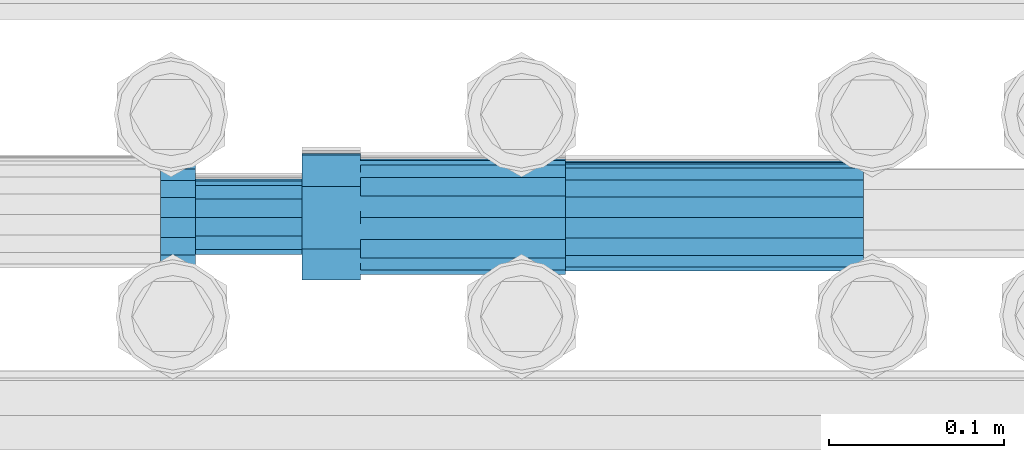
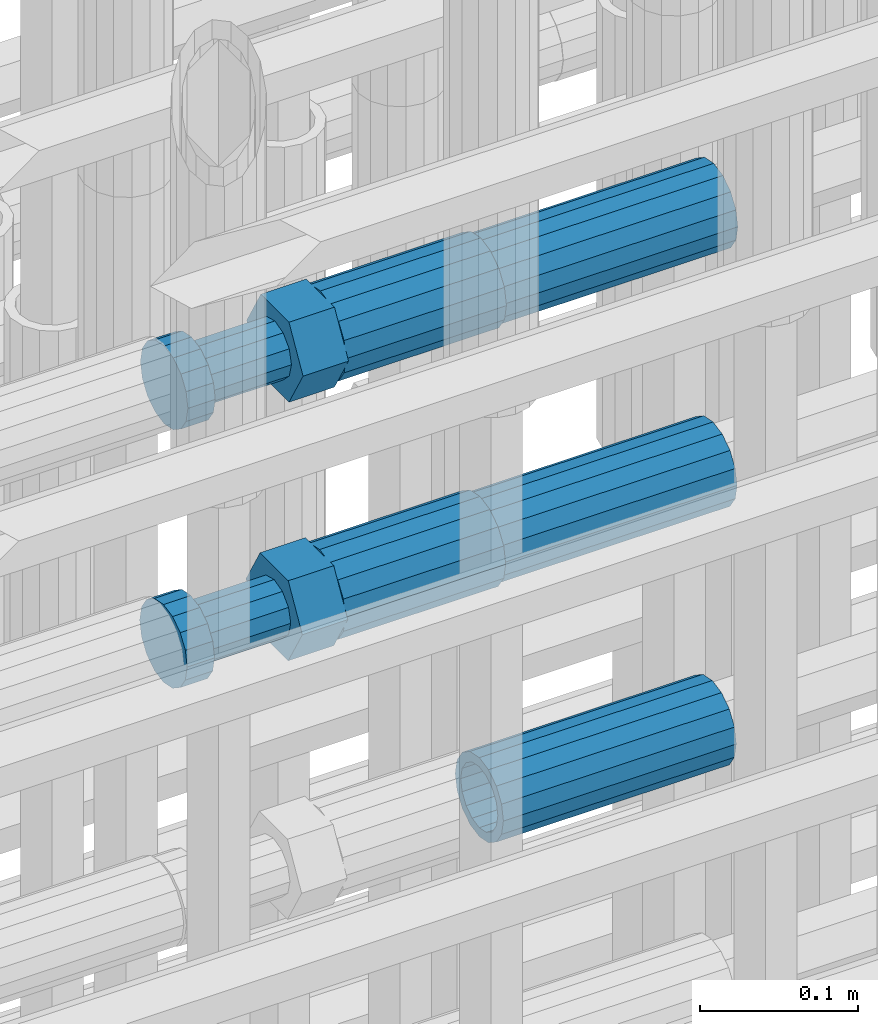
# One storey, part 26 of 119: 5 beams.
"""IFC2X3 building model written with IfcOpenShell, lengths in millimetres."""

from ifc_helpers import new_model, si_unit, frame, origin_with_axes, place, context, subcontext, project, spatial, faceted_brep, material, type_object, element, save


model = new_model("IFC2X3")

# Units and contexts
model_context = context("Model", 3, precision=1e-05, world=origin_with_axes())
body_context = subcontext(model_context, "Body", "Model", "MODEL_VIEW")
ifc_project = project(units=[si_unit("LENGTHUNIT", "METRE", prefix="MILLI"), si_unit("AREAUNIT", "SQUARE_METRE"), si_unit("VOLUMEUNIT", "CUBIC_METRE"), si_unit("MASSUNIT", "GRAM", prefix="KILO"), si_unit("TIMEUNIT", "SECOND"), si_unit("PLANEANGLEUNIT", "RADIAN"), si_unit("SOLIDANGLEUNIT", "STERADIAN"), si_unit("THERMODYNAMICTEMPERATUREUNIT", "DEGREE_CELSIUS"), si_unit("LUMINOUSINTENSITYUNIT", "LUMEN")], contexts=[model_context])

# Site, building, storey
site_placement = place(None, origin_with_axes())
site = spatial("IfcSite", under=ifc_project, at=site_placement, CompositionType="ELEMENT")
building_placement = place(site_placement, origin_with_axes())
building = spatial("IfcBuilding", under=site, at=building_placement, Name="Undefined", CompositionType="ELEMENT")
storey_placement = place(building_placement, origin_with_axes())
storey = spatial("IfcBuildingStorey", under=building, at=storey_placement, Name="Undefined", CompositionType="ELEMENT", Elevation=0.0)

# Beams
ifc_material = material(Name="STEEL/S275")
beam_type_1 = type_object("IfcBeamType", PredefinedType="NOTDEFINED")
beam_1_placement = place(storey_placement, frame((2035520.01345925, 6205210.28560864, 20746.6568409387), z_axis=(0.0, 0.0, 1.0), x_axis=(-0.999999999998145, -1.92600247614167e-06, 0.0)))
element("IfcBeam", 1, at=beam_1_placement, inside=storey, type_object=beam_type_1, material=ifc_material, Name="AG40N", context=body_context, shape_type="Brep", body=[
    faceted_brep([(1.62981450557709e-09, -23.4999999990687, 0.0), (7.45058059692383e-09, -21.7111690142192, 8.99306066057534), (170.000002125278, -21.711168999318, 8.99306066022245), (170.000002127141, -23.4999999844003, -3.66071617463604e-10), (4.65661287307739e-09, -16.6170093587134, 16.6170093578889), (170.000002122484, -16.6170093440451, 16.6170093575288), (1.86264514923096e-09, -8.99306066217832, 21.7111690140277), (170.000002118759, -8.99306064750999, 21.7111690136603), (2.3283064365387e-10, 9.31322574615479e-10, 23.5), (170.000002114102, 1.28056854009628e-08, 23.4999999996485), (-6.51925802230835e-09, 8.99306065868586, 21.7111690140241), (170.00000211224, 8.99306067335419, 21.7111690136639), (-7.45058059692383e-09, 16.6170093561523, 16.6170093578853), (170.000002109446, 16.6170093708206, 16.6170093575324), (-9.31322574615479e-09, 21.711169013055, 8.99306066057534), (170.000002108514, 21.7111690277234, 8.99306066022245), (-1.16415321826935e-09, 23.5000000009313, 0.0), (170.000002108514, 23.5000000144355, -3.66071617463604e-10), (-8.38190317153931e-09, 21.7111690151505, -8.99306066059444), (170.000002110377, 21.7111690300517, -8.9930606609546), (-5.58793544769287e-09, 16.6170093598776, -16.6170093579008), (170.000002113171, 16.6170093745459, -16.6170093582609), (-9.31322574615479e-10, 8.99306066334248, -21.7111690140396), (170.000002115965, 8.99306067801081, -21.7111690143961), (2.3283064365387e-10, 9.31322574615479e-10, -23.5), (170.00000211969, 1.7927959561348e-08, -23.5000000003843), (5.58793544769287e-09, -8.99306065752171, -21.7111690140396), (170.000002123415, -8.99306064285338, -21.7111690143961), (8.38190317153931e-09, -16.6170093549881, -16.6170093579008), (170.000002125278, -16.6170093403198, -16.6170093582646), (9.31322574615479e-09, -21.7111690121237, -8.99306066059444), (170.000002127141, -21.7111689972226, -8.9930606609546), (1.11758708953857e-08, -30.4999999990687, -9.54969436861575e-12), (1.30385160446167e-08, -28.1783257392235, -11.6718446871514), (170.000002129003, -28.1783257243223, -11.6718446875116), (170.000002129935, -30.4999999841675, -3.66071617463604e-10), (1.02445483207703e-08, -21.5667568228673, -21.5667568262129), (170.000002128072, -21.566756808199, -21.5667568265694), (7.45058059692383e-09, -11.6718446831219, -28.1783257416196), (170.000002125278, -11.6718446684536, -28.1783257419834), (3.72529029846191e-09, 3.95812094211578e-09, -30.5000000000277), (170.00000211969, 1.83936208486557e-08, -30.5000000003879), (-9.31322574615479e-10, 11.6718446905725, -28.1783257416232), (170.000002115965, 11.6718447052408, -28.1783257419797), (-6.51925802230835e-09, 21.5667568286881, -21.5667568262093), (170.000002110377, 21.5667568433564, -21.5667568265694), (-9.31322574615479e-09, 28.178325742716, -11.6718446871478), (170.000002108514, 28.1783257573843, -11.6718446875079), (-1.21071934700012e-08, 30.5, -5.91171556152403e-12), (170.000002106652, 30.5000000144355, -3.62433638656512e-10), (-1.21071934700012e-08, 28.1783257401548, 11.6718446871359), (170.00000210572, 28.1783257548232, 11.6718446867794), (-1.02445483207703e-08, 21.5667568240315, 21.5667568261974), (170.000002107583, 21.566756838467, 21.5667568258409), (-7.45058059692383e-09, 11.671844684286, 28.1783257416041), (170.000002110377, 11.6718446989544, 28.178325741244), (-2.79396772384644e-09, -2.56113708019257e-09, 30.5000000000159), (170.000002114102, 1.18743628263474e-08, 30.4999999996558), (1.86264514923096e-09, -11.6718446896411, 28.1783257416114), (170.000002118759, -11.67184467474, 28.178325741244), (7.45058059692383e-09, -21.5667568275239, 21.5667568261974), (170.000002123415, -21.5667568126228, 21.5667568258373), (1.02445483207703e-08, -28.1783257415518, 11.6718446871359), (170.000002127141, -28.1783257271163, 11.6718446867794)], [[[0, 1, 2, 3]], [[1, 4, 5, 2]], [[4, 6, 7, 5]], [[6, 8, 9, 7]], [[8, 10, 11, 9]], [[10, 12, 13, 11]], [[12, 14, 15, 13]], [[14, 16, 17, 15]], [[16, 18, 19, 17]], [[18, 20, 21, 19]], [[20, 22, 23, 21]], [[22, 24, 25, 23]], [[24, 26, 27, 25]], [[26, 28, 29, 27]], [[28, 30, 31, 29]], [[30, 0, 3, 31]], [[32, 33, 34, 35]], [[33, 36, 37, 34]], [[36, 38, 39, 37]], [[38, 40, 41, 39]], [[40, 42, 43, 41]], [[42, 44, 45, 43]], [[44, 46, 47, 45]], [[46, 48, 49, 47]], [[48, 50, 51, 49]], [[50, 52, 53, 51]], [[52, 54, 55, 53]], [[54, 56, 57, 55]], [[56, 58, 59, 57]], [[58, 60, 61, 59]], [[60, 62, 63, 61]], [[62, 32, 35, 63]], [[37, 39, 41, 43, 45, 47, 49, 51, 53, 55, 57, 59, 61, 63, 35, 34], [5, 7, 9, 11, 13, 15, 17, 19, 21, 23, 25, 27, 29, 31, 3, 2]], [[62, 60, 58, 56, 54, 52, 50, 48, 46, 44, 42, 40, 38, 36, 33, 32], [30, 28, 26, 24, 22, 20, 18, 16, 14, 12, 10, 8, 6, 4, 1, 0]]]),
])
beam_2_placement = place(storey_placement, frame((2035520.01345925, 6205211.20560864, 20546.6568409387), z_axis=(0.0, 0.0, 1.0), x_axis=(-0.999999999998145, -1.92600247614167e-06, 0.0)))
element("IfcBeam", 2, at=beam_2_placement, inside=storey, type_object=beam_type_1, material=ifc_material, Name="AG40N", context=body_context, shape_type="Brep", body=[
    faceted_brep([(1.62981450557709e-09, -23.4999999990687, 0.0), (7.45058059692383e-09, -21.7111690142192, 8.99306066057534), (170.000002125278, -21.711168999318, 8.99306066022245), (170.000002127141, -23.4999999844003, -3.66071617463604e-10), (4.65661287307739e-09, -16.6170093587134, 16.6170093578889), (170.000002122484, -16.6170093440451, 16.6170093575288), (1.86264514923096e-09, -8.99306066217832, 21.7111690140277), (170.000002118759, -8.99306064750999, 21.7111690136603), (2.3283064365387e-10, 9.31322574615479e-10, 23.5), (170.000002114102, 1.28056854009628e-08, 23.4999999996485), (-6.51925802230835e-09, 8.99306065868586, 21.7111690140241), (170.00000211224, 8.99306067335419, 21.7111690136639), (-7.45058059692383e-09, 16.6170093561523, 16.6170093578853), (170.000002109446, 16.6170093708206, 16.6170093575324), (-9.31322574615479e-09, 21.711169013055, 8.99306066057534), (170.000002108514, 21.7111690277234, 8.99306066022245), (-1.16415321826935e-09, 23.5000000009313, 0.0), (170.000002108514, 23.5000000144355, -3.66071617463604e-10), (-8.38190317153931e-09, 21.7111690151505, -8.99306066059444), (170.000002110377, 21.7111690300517, -8.9930606609546), (-5.58793544769287e-09, 16.6170093598776, -16.6170093579008), (170.000002113171, 16.6170093745459, -16.6170093582609), (-9.31322574615479e-10, 8.99306066334248, -21.7111690140396), (170.000002115965, 8.99306067801081, -21.7111690143961), (2.3283064365387e-10, 9.31322574615479e-10, -23.5), (170.00000211969, 1.7927959561348e-08, -23.5000000003843), (5.58793544769287e-09, -8.99306065752171, -21.7111690140396), (170.000002123415, -8.99306064285338, -21.7111690143961), (8.38190317153931e-09, -16.6170093549881, -16.6170093579008), (170.000002125278, -16.6170093403198, -16.6170093582646), (9.31322574615479e-09, -21.7111690121237, -8.99306066059444), (170.000002127141, -21.7111689972226, -8.9930606609546), (1.11758708953857e-08, -30.4999999990687, -9.54969436861575e-12), (1.30385160446167e-08, -28.1783257392235, -11.6718446871514), (170.000002129003, -28.1783257243223, -11.6718446875116), (170.000002129935, -30.4999999841675, -3.66071617463604e-10), (1.02445483207703e-08, -21.5667568228673, -21.5667568262129), (170.000002128072, -21.566756808199, -21.5667568265694), (7.45058059692383e-09, -11.6718446831219, -28.1783257416196), (170.000002125278, -11.6718446684536, -28.1783257419834), (3.72529029846191e-09, 3.95812094211578e-09, -30.5000000000277), (170.00000211969, 1.83936208486557e-08, -30.5000000003879), (-9.31322574615479e-10, 11.6718446905725, -28.1783257416232), (170.000002115965, 11.6718447052408, -28.1783257419797), (-6.51925802230835e-09, 21.5667568286881, -21.5667568262093), (170.000002110377, 21.5667568433564, -21.5667568265694), (-9.31322574615479e-09, 28.178325742716, -11.6718446871478), (170.000002108514, 28.1783257573843, -11.6718446875079), (-1.21071934700012e-08, 30.5, -5.91171556152403e-12), (170.000002106652, 30.5000000144355, -3.62433638656512e-10), (-1.21071934700012e-08, 28.1783257401548, 11.6718446871359), (170.00000210572, 28.1783257548232, 11.6718446867794), (-1.02445483207703e-08, 21.5667568240315, 21.5667568261974), (170.000002107583, 21.566756838467, 21.5667568258409), (-7.45058059692383e-09, 11.671844684286, 28.1783257416041), (170.000002110377, 11.6718446989544, 28.178325741244), (-2.79396772384644e-09, -2.56113708019257e-09, 30.5000000000159), (170.000002114102, 1.18743628263474e-08, 30.4999999996558), (1.86264514923096e-09, -11.6718446896411, 28.1783257416114), (170.000002118759, -11.67184467474, 28.178325741244), (7.45058059692383e-09, -21.5667568275239, 21.5667568261974), (170.000002123415, -21.5667568126228, 21.5667568258373), (1.02445483207703e-08, -28.1783257415518, 11.6718446871359), (170.000002127141, -28.1783257271163, 11.6718446867794)], [[[0, 1, 2, 3]], [[1, 4, 5, 2]], [[4, 6, 7, 5]], [[6, 8, 9, 7]], [[8, 10, 11, 9]], [[10, 12, 13, 11]], [[12, 14, 15, 13]], [[14, 16, 17, 15]], [[16, 18, 19, 17]], [[18, 20, 21, 19]], [[20, 22, 23, 21]], [[22, 24, 25, 23]], [[24, 26, 27, 25]], [[26, 28, 29, 27]], [[28, 30, 31, 29]], [[30, 0, 3, 31]], [[32, 33, 34, 35]], [[33, 36, 37, 34]], [[36, 38, 39, 37]], [[38, 40, 41, 39]], [[40, 42, 43, 41]], [[42, 44, 45, 43]], [[44, 46, 47, 45]], [[46, 48, 49, 47]], [[48, 50, 51, 49]], [[50, 52, 53, 51]], [[52, 54, 55, 53]], [[54, 56, 57, 55]], [[56, 58, 59, 57]], [[58, 60, 61, 59]], [[60, 62, 63, 61]], [[62, 32, 35, 63]], [[37, 39, 41, 43, 45, 47, 49, 51, 53, 55, 57, 59, 61, 63, 35, 34], [5, 7, 9, 11, 13, 15, 17, 19, 21, 23, 25, 27, 29, 31, 3, 2]], [[62, 60, 58, 56, 54, 52, 50, 48, 46, 44, 42, 40, 38, 36, 33, 32], [30, 28, 26, 24, 22, 20, 18, 16, 14, 12, 10, 8, 6, 4, 1, 0]]]),
])
beam_3_placement = place(storey_placement, frame((2035520.01345925, 6205212.13560864, 20346.6568409387), z_axis=(0.0, 0.0, 1.0), x_axis=(-0.999999999998145, -1.92600247614167e-06, 0.0)))
element("IfcBeam", 3, at=beam_3_placement, inside=storey, type_object=beam_type_1, material=ifc_material, Name="AG40N", context=body_context, shape_type="Brep", body=[
    faceted_brep([(1.62981450557709e-09, -23.4999999990687, 0.0), (7.45058059692383e-09, -21.7111690142192, 8.99306066057534), (170.000002125278, -21.711168999318, 8.99306066022245), (170.000002127141, -23.4999999844003, -3.66071617463604e-10), (4.65661287307739e-09, -16.6170093587134, 16.6170093578889), (170.000002122484, -16.6170093440451, 16.6170093575288), (1.86264514923096e-09, -8.99306066217832, 21.7111690140277), (170.000002118759, -8.99306064750999, 21.7111690136603), (2.3283064365387e-10, 9.31322574615479e-10, 23.5), (170.000002114102, 1.28056854009628e-08, 23.4999999996485), (-6.51925802230835e-09, 8.99306065868586, 21.7111690140241), (170.00000211224, 8.99306067335419, 21.7111690136639), (-7.45058059692383e-09, 16.6170093561523, 16.6170093578853), (170.000002109446, 16.6170093708206, 16.6170093575324), (-9.31322574615479e-09, 21.711169013055, 8.99306066057534), (170.000002108514, 21.7111690277234, 8.99306066022245), (-1.16415321826935e-09, 23.5000000009313, 0.0), (170.000002108514, 23.5000000144355, -3.66071617463604e-10), (-8.38190317153931e-09, 21.7111690151505, -8.99306066059444), (170.000002110377, 21.7111690300517, -8.9930606609546), (-5.58793544769287e-09, 16.6170093598776, -16.6170093579008), (170.000002113171, 16.6170093745459, -16.6170093582609), (-9.31322574615479e-10, 8.99306066334248, -21.7111690140396), (170.000002115965, 8.99306067801081, -21.7111690143961), (2.3283064365387e-10, 9.31322574615479e-10, -23.5), (170.00000211969, 1.7927959561348e-08, -23.5000000003843), (5.58793544769287e-09, -8.99306065752171, -21.7111690140396), (170.000002123415, -8.99306064285338, -21.7111690143961), (8.38190317153931e-09, -16.6170093549881, -16.6170093579008), (170.000002125278, -16.6170093403198, -16.6170093582646), (9.31322574615479e-09, -21.7111690121237, -8.99306066059444), (170.000002127141, -21.7111689972226, -8.9930606609546), (1.11758708953857e-08, -30.4999999990687, -9.54969436861575e-12), (1.30385160446167e-08, -28.1783257392235, -11.6718446871514), (170.000002129003, -28.1783257243223, -11.6718446875116), (170.000002129935, -30.4999999841675, -3.66071617463604e-10), (1.02445483207703e-08, -21.5667568228673, -21.5667568262129), (170.000002128072, -21.566756808199, -21.5667568265694), (7.45058059692383e-09, -11.6718446831219, -28.1783257416196), (170.000002125278, -11.6718446684536, -28.1783257419834), (3.72529029846191e-09, 3.95812094211578e-09, -30.5000000000277), (170.00000211969, 1.83936208486557e-08, -30.5000000003879), (-9.31322574615479e-10, 11.6718446905725, -28.1783257416232), (170.000002115965, 11.6718447052408, -28.1783257419797), (-6.51925802230835e-09, 21.5667568286881, -21.5667568262093), (170.000002110377, 21.5667568433564, -21.5667568265694), (-9.31322574615479e-09, 28.178325742716, -11.6718446871478), (170.000002108514, 28.1783257573843, -11.6718446875079), (-1.21071934700012e-08, 30.5, -5.91171556152403e-12), (170.000002106652, 30.5000000144355, -3.62433638656512e-10), (-1.21071934700012e-08, 28.1783257401548, 11.6718446871359), (170.00000210572, 28.1783257548232, 11.6718446867794), (-1.02445483207703e-08, 21.5667568240315, 21.5667568261974), (170.000002107583, 21.566756838467, 21.5667568258409), (-7.45058059692383e-09, 11.671844684286, 28.1783257416041), (170.000002110377, 11.6718446989544, 28.178325741244), (-2.79396772384644e-09, -2.56113708019257e-09, 30.5000000000159), (170.000002114102, 1.18743628263474e-08, 30.4999999996558), (1.86264514923096e-09, -11.6718446896411, 28.1783257416114), (170.000002118759, -11.67184467474, 28.178325741244), (7.45058059692383e-09, -21.5667568275239, 21.5667568261974), (170.000002123415, -21.5667568126228, 21.5667568258373), (1.02445483207703e-08, -28.1783257415518, 11.6718446871359), (170.000002127141, -28.1783257271163, 11.6718446867794)], [[[0, 1, 2, 3]], [[1, 4, 5, 2]], [[4, 6, 7, 5]], [[6, 8, 9, 7]], [[8, 10, 11, 9]], [[10, 12, 13, 11]], [[12, 14, 15, 13]], [[14, 16, 17, 15]], [[16, 18, 19, 17]], [[18, 20, 21, 19]], [[20, 22, 23, 21]], [[22, 24, 25, 23]], [[24, 26, 27, 25]], [[26, 28, 29, 27]], [[28, 30, 31, 29]], [[30, 0, 3, 31]], [[32, 33, 34, 35]], [[33, 36, 37, 34]], [[36, 38, 39, 37]], [[38, 40, 41, 39]], [[40, 42, 43, 41]], [[42, 44, 45, 43]], [[44, 46, 47, 45]], [[46, 48, 49, 47]], [[48, 50, 51, 49]], [[50, 52, 53, 51]], [[52, 54, 55, 53]], [[54, 56, 57, 55]], [[56, 58, 59, 57]], [[58, 60, 61, 59]], [[60, 62, 63, 61]], [[62, 32, 35, 63]], [[37, 39, 41, 43, 45, 47, 49, 51, 53, 55, 57, 59, 61, 63, 35, 34], [5, 7, 9, 11, 13, 15, 17, 19, 21, 23, 25, 27, 29, 31, 3, 2]], [[62, 60, 58, 56, 54, 52, 50, 48, 46, 44, 42, 40, 38, 36, 33, 32], [30, 28, 26, 24, 22, 20, 18, 16, 14, 12, 10, 8, 6, 4, 1, 0]]]),
])
beam_type_2 = type_object("IfcBeamType", Name="ROD65", PredefinedType="NOTDEFINED")
beam_4_placement = place(storey_placement, frame((2035350.01345925, 6205210.28544664, 20746.6568409387), z_axis=(0.0, 0.0, 1.0), x_axis=(-0.999999999998145, -1.92600247614167e-06, 0.0)))
element("IfcBeam", 4, at=beam_4_placement, inside=storey, type_object=beam_type_2, material=ifc_material, Name="AGB40", ObjectType="ROD65", context=body_context, shape_type="Brep", body=[
    faceted_brep([(116.999999999069, 17.8249999252148, 30.8738056446964), (116.999999998137, 22.0056957420893, 23.632628078838), (116.999999999069, 12.4372115600854, 30.0260848066173), (116.999999999069, 8.17543111252598, 30.8738056446964), (117.000000000931, -17.8250000746921, 30.8738056446964), (150.200000001118, -17.8250000723638, 30.8738056446964), (150.199999999255, 17.8249999275431, 30.8738056446964), (117.000000000931, -8.17543109622784, 30.8738056446964), (117.000000001863, -22.0056959956419, 23.6326278985034), (117.000000000931, -12.4372115437873, 30.0260848066173), (117.000000001863, -35.6500000746455, -2.18278728425503e-10), (150.200000002049, -35.6500000723172, -2.18278728425503e-10), (117.000000001863, -30.8443149488885, 8.32369080289209), (117.000000001863, -30.8443149488885, -8.32369080355784), (117.000000002794, -32.4999999918509, 0.0), (117.000000000931, -17.8250000746921, -30.873805645133), (150.200000001118, -17.8250000723638, -30.873805645133), (117.000000001863, -22.0056959961075, -23.6326278982269), (117.000000000931, -8.17543109389953, -30.873805645133), (117.000000000931, -12.4372115437873, -30.0260848066173), (116.999999999069, 17.8249999252148, -30.873805645133), (150.199999999255, 17.8249999275431, -30.873805645133), (116.999999999069, 8.17543111019768, -30.873805645133), (116.999999999069, 12.4372115600854, -30.0260848066173), (116.999999998137, 22.005695742555, -23.6326280785652), (116.999999998137, 35.6499999251682, -2.18278728425503e-10), (150.199999998324, 35.6499999277294, -2.18278728425503e-10), (116.999999998137, 30.8443150522653, -8.32369036550881), (116.999999997206, 32.5000000081491, 0.0), (116.999999998137, 30.8443150522653, 8.32369036483942), (1.86264514923096e-09, -22.9809703885112, 22.9809703885621), (1.86264514923096e-09, -30.0260848065373, 12.4372115518672), (117.000000001863, -30.0260847983882, 12.4372115518672), (117.000000001863, -22.9809703803621, 22.9809703885621), (-1.86264514923096e-09, 22.9809703885112, -22.9809703885621), (-1.86264514923096e-09, 30.0260848065373, -12.4372115518672), (116.999999998137, 30.0260848146863, -12.4372115518672), (116.999999998137, 22.9809703966603, -22.9809703885621), (1.86264514923096e-09, -30.0260848065373, -12.4372115518672), (1.86264514923096e-09, -22.9809703885112, -22.9809703885621), (117.000000001863, -22.9809703803621, -22.9809703885621), (117.000000001863, -30.0260847983882, -12.4372115518672), (9.31322574615479e-10, -12.4372115519363, 30.0260848066173), (0.0, 0.0, 32.5), (-9.31322574615479e-10, 12.4372115519363, 30.0260848066173), (-1.86264514923096e-09, 22.9809703885112, 22.9809703885621), (-1.86264514923096e-09, 30.0260848065373, 12.4372115518672), (-2.79396772384644e-09, 32.5, 0.0), (-9.31322574615479e-10, 12.4372115519363, -30.0260848066173), (0.0, 0.0, -32.5), (9.31322574615479e-10, -12.4372115519363, -30.0260848066173), (2.79396772384644e-09, -32.5, 0.0), (116.999999998137, 22.9809703966603, 22.9809703885621), (116.999999998137, 30.0260848146863, 12.4372115518672), (117.0, 8.14907252788544e-09, -32.5), (117.0, 8.14907252788544e-09, 32.5), (150.200000000186, -10.5000000959262, 18.1865334791873), (150.199999999255, -9.59262251853943e-08, 20.9999999997126), (150.199999998324, 10.4999999040738, 18.1865334791873), (150.199999997392, 18.1865333835594, 10.4999999997126), (150.199999997392, 20.9999999040738, -2.87400325760245e-10), (150.199999997392, 18.1865333835594, -10.5000000002874), (150.199999998324, 10.4999999040738, -18.1865334797621), (150.199999999255, -9.59262251853943e-08, -21.0000000002874), (150.200000000186, -10.5000000959262, -18.1865334797621), (150.200000000186, -18.1865335754119, -10.5000000002874), (150.200000001118, -21.0000000959262, -2.87400325760245e-10), (150.200000000186, -18.1865335754119, 10.4999999997126), (210.979999999516, 10.4999999082647, 18.1865334791873), (210.979999999516, -9.17352735996246e-08, 20.9999999997126), (210.979999997653, 18.1865333877504, 10.4999999997126), (210.979999997653, 20.9999999082647, -2.87400325760245e-10), (210.979999997653, 18.1865333877504, -10.5000000002874), (210.979999999516, 10.4999999082647, -18.1865334797621), (210.979999999516, -9.17352735996246e-08, -21.0000000002874), (210.979999999516, -10.5000000917353, -18.1865334797621), (210.980000000447, -18.1865335712209, -10.5000000002874), (210.980000001378, -21.0000000917353, -2.87400325760245e-10), (210.980000000447, -18.1865335712209, 10.4999999997126), (210.979999999516, -10.5000000917353, 18.1865334791873), (211.001368402503, -27.7269939335529, -11.4911163272045), (211.003082515672, -21.2238095656503, -21.2238154190527), (231.002518340945, -21.2131946226582, -21.2132004554769), (231.000804228708, -27.7163789905608, -11.4805013636287), (211.001368415542, -11.4911086384673, -27.7269970399575), (231.000804241747, -11.4804936954752, -27.7163820763781), (210.996487061493, -0.0106066407170147, -30.0106107396168), (230.995922887698, 8.30227509140968e-06, -29.999995776041), (210.98918159306, 11.4698940692469, -27.7269970332745), (230.988617419265, 11.4805090120062, -27.7163820696951), (210.980564201251, 21.2025913291145, -21.2238154067054), (230.980000027455, 21.2132062721066, -21.2132004431296), (210.971946807578, 27.7057702087332, -11.4911163110701), (230.971382633783, 27.7163851517253, -11.4805013474943), (210.964641331695, 29.9893806746695, -0.0106149565435771), (230.9640771579, 29.9999956176616, 7.03221303410828e-09), (210.959759964608, 27.7057637346443, 11.4698863966551), (230.959195790812, 27.7163786776364, 11.4805013602345), (210.958045851439, 21.2025793667417, 21.2025854885032), (230.957481677644, 21.2131943097338, 21.2132004520827), (210.959759951569, 11.4698784395587, 27.705767109408), (230.959195776843, 11.4804933823179, 27.7163820729838), (210.964641305618, -0.0106235581915826, 29.9893808090674), (230.964077131823, -8.61519947648048e-06, 29.9999957726432), (210.971946774051, -11.4911242681555, 27.7057671027251), (230.971382599324, -11.4805093251634, 27.7163820663009), (210.98056416586, -21.2238215280231, 21.2025854761559), (230.979999991134, -21.2132065852638, 21.2132004397354), (210.989181559533, -27.7270004076418, 11.4698863805206), (230.988617384806, -27.7163854646496, 11.4805013441), (210.996487035416, -30.0106108735781, -0.0106149740058754), (230.995922861621, -29.999995930586, -1.04300852399319e-08)], [[[0, 1, 2, 3]], [[4, 5, 6, 0, 3, 7]], [[8, 4, 7, 9]], [[10, 11, 5, 4, 8, 12]], [[13, 10, 12, 14]], [[15, 16, 11, 10, 13, 17]], [[18, 15, 17, 19]], [[20, 21, 16, 15, 18, 22]], [[20, 22, 23, 24]], [[25, 26, 21, 20, 24, 27]], [[25, 27, 28, 29]], [[30, 31, 32, 33]], [[34, 35, 36, 37]], [[38, 39, 40, 41]], [[31, 30, 42, 43, 44, 45, 46, 47, 35, 34, 48, 49, 50, 39, 38, 51]], [[46, 45, 52, 53]], [[28, 47, 46, 53, 29]], [[27, 36, 35, 47, 28]], [[24, 37, 36, 27]], [[23, 48, 34, 37, 24]], [[22, 54, 49, 48, 23]], [[18, 54, 22]], [[19, 50, 49, 54, 18]], [[17, 40, 39, 50, 19]], [[13, 41, 40, 17]], [[14, 51, 38, 41, 13]], [[12, 32, 31, 51, 14]], [[8, 33, 32, 12]], [[9, 42, 30, 33, 8]], [[7, 55, 43, 42, 9]], [[3, 55, 7]], [[2, 44, 43, 55, 3]], [[1, 52, 45, 44, 2]], [[29, 53, 52, 1]], [[0, 6, 26, 25, 29, 1]], [[5, 11, 16, 21, 26, 6], [56, 57, 58, 59, 60, 61, 62, 63, 64, 65, 66, 67]], [[68, 58, 57, 69]], [[70, 59, 58, 68]], [[71, 60, 59, 70]], [[72, 61, 60, 71]], [[73, 62, 61, 72]], [[74, 63, 62, 73]], [[75, 64, 63, 74]], [[76, 65, 64, 75]], [[77, 66, 65, 76]], [[78, 67, 66, 77]], [[79, 56, 67, 78]], [[69, 57, 56, 79]], [[80, 81, 82, 83]], [[81, 84, 85, 82]], [[84, 86, 87, 85]], [[86, 88, 89, 87]], [[88, 90, 91, 89]], [[90, 92, 93, 91]], [[92, 94, 95, 93]], [[94, 96, 97, 95]], [[96, 98, 99, 97]], [[98, 100, 101, 99]], [[100, 102, 103, 101]], [[102, 104, 105, 103]], [[104, 106, 107, 105]], [[106, 108, 109, 107]], [[108, 110, 111, 109]], [[82, 85, 87, 89, 91, 93, 95, 97, 99, 101, 103, 105, 107, 109, 111, 83]], [[110, 80, 83, 111]], [[108, 106, 104, 102, 100, 98, 96, 94, 92, 90, 88, 86, 84, 81, 80, 110], [78, 77, 76, 75, 74, 73, 72, 71, 70, 68, 69, 79]]]),
])
beam_5_placement = place(storey_placement, frame((2035350.01345925, 6205211.20544664, 20546.6568409387), z_axis=(0.0, 0.0, 1.0), x_axis=(-0.999999999998145, -1.92600247614167e-06, 0.0)))
element("IfcBeam", 5, at=beam_5_placement, inside=storey, type_object=beam_type_2, material=ifc_material, Name="AGB40", ObjectType="ROD65", context=body_context, shape_type="Brep", body=[
    faceted_brep([(116.999999999069, 17.8249999252148, 30.8738056446964), (116.999999998137, 22.0056957420893, 23.632628078838), (116.999999999069, 12.4372115600854, 30.0260848066173), (116.999999999069, 8.17543111252598, 30.8738056446964), (117.000000000931, -17.8250000746921, 30.8738056446964), (150.200000001118, -17.8250000723638, 30.8738056446964), (150.199999999255, 17.8249999275431, 30.8738056446964), (117.000000000931, -8.17543109622784, 30.8738056446964), (117.000000001863, -22.0056959956419, 23.6326278985034), (117.000000000931, -12.4372115437873, 30.0260848066173), (117.000000001863, -35.6500000746455, -2.18278728425503e-10), (150.200000002049, -35.6500000723172, -2.18278728425503e-10), (117.000000001863, -30.8443149488885, 8.32369080289209), (117.000000001863, -30.8443149488885, -8.32369080355784), (117.000000002794, -32.4999999918509, 0.0), (117.000000000931, -17.8250000746921, -30.873805645133), (150.200000001118, -17.8250000723638, -30.873805645133), (117.000000001863, -22.0056959961075, -23.6326278982269), (117.000000000931, -8.17543109389953, -30.873805645133), (117.000000000931, -12.4372115437873, -30.0260848066173), (116.999999999069, 17.8249999252148, -30.873805645133), (150.199999999255, 17.8249999275431, -30.873805645133), (116.999999999069, 8.17543111019768, -30.873805645133), (116.999999999069, 12.4372115600854, -30.0260848066173), (116.999999998137, 22.005695742555, -23.6326280785652), (116.999999998137, 35.6499999251682, -2.18278728425503e-10), (150.199999998324, 35.6499999277294, -2.18278728425503e-10), (116.999999998137, 30.8443150522653, -8.32369036550881), (116.999999997206, 32.5000000081491, 0.0), (116.999999998137, 30.8443150522653, 8.32369036483942), (1.86264514923096e-09, -22.9809703885112, 22.9809703885621), (1.86264514923096e-09, -30.0260848065373, 12.4372115518672), (117.000000001863, -30.0260847983882, 12.4372115518672), (117.000000001863, -22.9809703803621, 22.9809703885621), (-1.86264514923096e-09, 22.9809703885112, -22.9809703885621), (-1.86264514923096e-09, 30.0260848065373, -12.4372115518672), (116.999999998137, 30.0260848146863, -12.4372115518672), (116.999999998137, 22.9809703966603, -22.9809703885621), (1.86264514923096e-09, -30.0260848065373, -12.4372115518672), (1.86264514923096e-09, -22.9809703885112, -22.9809703885621), (117.000000001863, -22.9809703803621, -22.9809703885621), (117.000000001863, -30.0260847983882, -12.4372115518672), (9.31322574615479e-10, -12.4372115519363, 30.0260848066173), (0.0, 0.0, 32.5), (-9.31322574615479e-10, 12.4372115519363, 30.0260848066173), (-1.86264514923096e-09, 22.9809703885112, 22.9809703885621), (-1.86264514923096e-09, 30.0260848065373, 12.4372115518672), (-2.79396772384644e-09, 32.5, 0.0), (-9.31322574615479e-10, 12.4372115519363, -30.0260848066173), (0.0, 0.0, -32.5), (9.31322574615479e-10, -12.4372115519363, -30.0260848066173), (2.79396772384644e-09, -32.5, 0.0), (116.999999998137, 22.9809703966603, 22.9809703885621), (116.999999998137, 30.0260848146863, 12.4372115518672), (117.0, 8.14907252788544e-09, -32.5), (117.0, 8.14907252788544e-09, 32.5), (150.200000000186, -10.5000000959262, 18.1865334791873), (150.199999999255, -9.59262251853943e-08, 20.9999999997126), (150.199999998324, 10.4999999040738, 18.1865334791873), (150.199999997392, 18.1865333835594, 10.4999999997126), (150.199999997392, 20.9999999040738, -2.87400325760245e-10), (150.199999997392, 18.1865333835594, -10.5000000002874), (150.199999998324, 10.4999999040738, -18.1865334797621), (150.199999999255, -9.59262251853943e-08, -21.0000000002874), (150.200000000186, -10.5000000959262, -18.1865334797621), (150.200000000186, -18.1865335754119, -10.5000000002874), (150.200000001118, -21.0000000959262, -2.87400325760245e-10), (150.200000000186, -18.1865335754119, 10.4999999997126), (210.979999999516, 10.4999999082647, 18.1865334791873), (210.979999999516, -9.17352735996246e-08, 20.9999999997126), (210.979999997653, 18.1865333877504, 10.4999999997126), (210.979999997653, 20.9999999082647, -2.87400325760245e-10), (210.979999997653, 18.1865333877504, -10.5000000002874), (210.979999999516, 10.4999999082647, -18.1865334797621), (210.979999999516, -9.17352735996246e-08, -21.0000000002874), (210.979999999516, -10.5000000917353, -18.1865334797621), (210.980000000447, -18.1865335712209, -10.5000000002874), (210.980000001378, -21.0000000917353, -2.87400325760245e-10), (210.980000000447, -18.1865335712209, 10.4999999997126), (210.979999999516, -10.5000000917353, 18.1865334791873), (211.001368402503, -27.7269939335529, -11.4911163272045), (211.003082515672, -21.2238095656503, -21.2238154190527), (231.002518340945, -21.2131946226582, -21.2132004554769), (231.000804228708, -27.7163789905608, -11.4805013636287), (211.001368415542, -11.4911086384673, -27.7269970399575), (231.000804241747, -11.4804936954752, -27.7163820763781), (210.996487061493, -0.0106066407170147, -30.0106107396168), (230.995922887698, 8.30227509140968e-06, -29.999995776041), (210.98918159306, 11.4698940692469, -27.7269970332745), (230.988617419265, 11.4805090120062, -27.7163820696951), (210.980564201251, 21.2025913291145, -21.2238154067054), (230.980000027455, 21.2132062721066, -21.2132004431296), (210.971946807578, 27.7057702087332, -11.4911163110701), (230.971382633783, 27.7163851517253, -11.4805013474943), (210.964641331695, 29.9893806746695, -0.0106149565435771), (230.9640771579, 29.9999956176616, 7.03221303410828e-09), (210.959759964608, 27.7057637346443, 11.4698863966551), (230.959195790812, 27.7163786776364, 11.4805013602345), (210.958045851439, 21.2025793667417, 21.2025854885032), (230.957481677644, 21.2131943097338, 21.2132004520827), (210.959759951569, 11.4698784395587, 27.705767109408), (230.959195776843, 11.4804933823179, 27.7163820729838), (210.964641305618, -0.0106235581915826, 29.9893808090674), (230.964077131823, -8.61519947648048e-06, 29.9999957726432), (210.971946774051, -11.4911242681555, 27.7057671027251), (230.971382599324, -11.4805093251634, 27.7163820663009), (210.98056416586, -21.2238215280231, 21.2025854761559), (230.979999991134, -21.2132065852638, 21.2132004397354), (210.989181559533, -27.7270004076418, 11.4698863805206), (230.988617384806, -27.7163854646496, 11.4805013441), (210.996487035416, -30.0106108735781, -0.0106149740058754), (230.995922861621, -29.999995930586, -1.04300852399319e-08)], [[[0, 1, 2, 3]], [[4, 5, 6, 0, 3, 7]], [[8, 4, 7, 9]], [[10, 11, 5, 4, 8, 12]], [[13, 10, 12, 14]], [[15, 16, 11, 10, 13, 17]], [[18, 15, 17, 19]], [[20, 21, 16, 15, 18, 22]], [[20, 22, 23, 24]], [[25, 26, 21, 20, 24, 27]], [[25, 27, 28, 29]], [[30, 31, 32, 33]], [[34, 35, 36, 37]], [[38, 39, 40, 41]], [[31, 30, 42, 43, 44, 45, 46, 47, 35, 34, 48, 49, 50, 39, 38, 51]], [[46, 45, 52, 53]], [[28, 47, 46, 53, 29]], [[27, 36, 35, 47, 28]], [[24, 37, 36, 27]], [[23, 48, 34, 37, 24]], [[22, 54, 49, 48, 23]], [[18, 54, 22]], [[19, 50, 49, 54, 18]], [[17, 40, 39, 50, 19]], [[13, 41, 40, 17]], [[14, 51, 38, 41, 13]], [[12, 32, 31, 51, 14]], [[8, 33, 32, 12]], [[9, 42, 30, 33, 8]], [[7, 55, 43, 42, 9]], [[3, 55, 7]], [[2, 44, 43, 55, 3]], [[1, 52, 45, 44, 2]], [[29, 53, 52, 1]], [[0, 6, 26, 25, 29, 1]], [[5, 11, 16, 21, 26, 6], [56, 57, 58, 59, 60, 61, 62, 63, 64, 65, 66, 67]], [[68, 58, 57, 69]], [[70, 59, 58, 68]], [[71, 60, 59, 70]], [[72, 61, 60, 71]], [[73, 62, 61, 72]], [[74, 63, 62, 73]], [[75, 64, 63, 74]], [[76, 65, 64, 75]], [[77, 66, 65, 76]], [[78, 67, 66, 77]], [[79, 56, 67, 78]], [[69, 57, 56, 79]], [[80, 81, 82, 83]], [[81, 84, 85, 82]], [[84, 86, 87, 85]], [[86, 88, 89, 87]], [[88, 90, 91, 89]], [[90, 92, 93, 91]], [[92, 94, 95, 93]], [[94, 96, 97, 95]], [[96, 98, 99, 97]], [[98, 100, 101, 99]], [[100, 102, 103, 101]], [[102, 104, 105, 103]], [[104, 106, 107, 105]], [[106, 108, 109, 107]], [[108, 110, 111, 109]], [[82, 85, 87, 89, 91, 93, 95, 97, 99, 101, 103, 105, 107, 109, 111, 83]], [[110, 80, 83, 111]], [[108, 106, 104, 102, 100, 98, 96, 94, 92, 90, 88, 86, 84, 81, 80, 110], [78, 77, 76, 75, 74, 73, 72, 71, 70, 68, 69, 79]]]),
])

save(model, "model.ifc")
